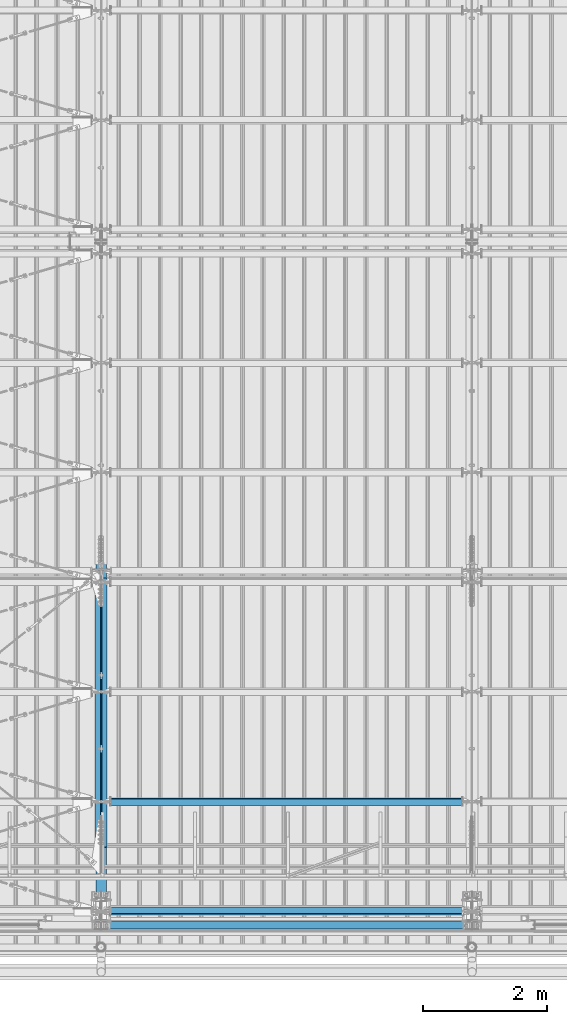
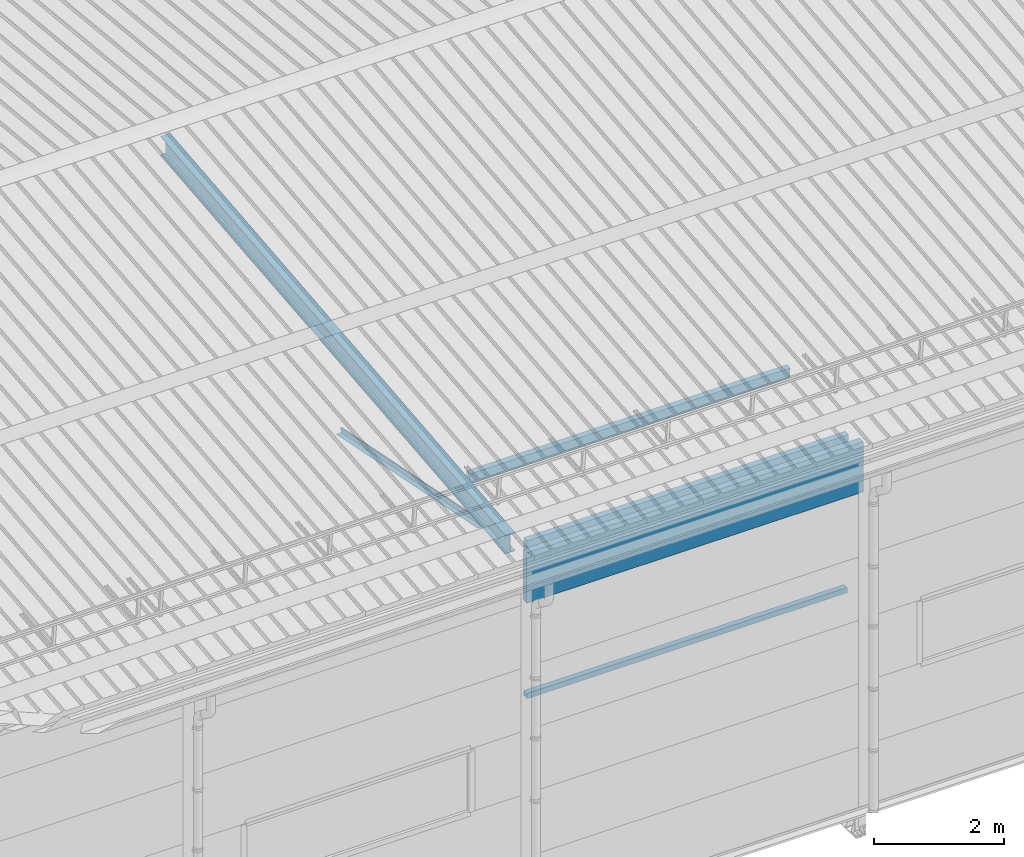
# One storey, part 243 of 709: 7 beams, 7 elements without a shape of their own.
"""IFC4 building model written with IfcOpenShell, lengths in millimetres."""

from ifc_helpers import new_model, si_unit, direction, frame, origin_with_axes, place, context, subcontext, project, spatial, polygons, material, element, aggregate, save


model = new_model("IFC4")

# Units and contexts
model_context = context("Model", 3, precision=0.2, world=origin_with_axes(), true_north=direction((0.0, 1.0)))
body_context = subcontext(model_context, "Body", "Model", "MODEL_VIEW")
ifc_project = project(units=[si_unit("LENGTHUNIT", "METRE", prefix="MILLI"), si_unit("AREAUNIT", "SQUARE_METRE"), si_unit("VOLUMEUNIT", "CUBIC_METRE"), si_unit("MASSUNIT", "GRAM", prefix="KILO"), si_unit("TIMEUNIT", "SECOND"), si_unit("PLANEANGLEUNIT", "RADIAN"), si_unit("SOLIDANGLEUNIT", "STERADIAN"), si_unit("THERMODYNAMICTEMPERATUREUNIT", "DEGREE_CELSIUS"), si_unit("LUMINOUSINTENSITYUNIT", "LUMEN")], contexts=[model_context])

# Site, building, storey
site_placement = place(None, origin_with_axes())
site = spatial("IfcSite", under=ifc_project, at=site_placement, CompositionType="ELEMENT")
building_placement = place(site_placement, origin_with_axes())
building = spatial("IfcBuilding", under=site, at=building_placement, Name="Undefined", CompositionType="ELEMENT")
storey_placement = place(building_placement, origin_with_axes())
storey = spatial("IfcBuildingStorey", under=building, at=storey_placement, Name="Undefined", CompositionType="ELEMENT", Elevation=0.0)

# Assembly, beam
assembly_1_placement = place(storey_placement, frame((10000.0, 346.0, 7089.70002), z_axis=(1.0, 0.0, 0.0), x_axis=(0.0, 0.9950371902, 0.099503719)))
assembly_1 = element("IfcElementAssembly", 1, at=assembly_1_placement, inside=storey)
ifc_material_1 = material(Name="C355-5", Category="STEEL")
beam_1_placement = place(assembly_1_placement, origin_with_axes())
beam_1 = element("IfcBeam", 2, at=beam_1_placement, material=ifc_material_1, ObjectType="432", context=body_context, shape_type="Tessellation", body=[
    polygons([(3.80474, -173.0, -87.0), (4.70474, -164.0, -87.0), (10665.6128, -164.0, -87.0), (10664.7128, -173.0, -87.0), (4.70474, -164.0, -3.0), (10665.6128, -164.0, -3.0), (37.50474, 164.0, -3.0), (10698.4128, 164.0, -3.0), (37.50474, 164.0, -87.0), (10698.4128, 164.0, -87.0), (38.40474, 173.0, -87.0), (10699.3128, 173.0, -87.0), (38.40474, 173.0, 87.0), (10699.3128, 173.0, 87.0), (37.50474, 164.0, 87.0), (10698.4128, 164.0, 87.0), (37.50474, 164.0, 3.0), (10698.4128, 164.0, 3.0), (4.70474, -164.0, 3.0), (10665.6128, -164.0, 3.0), (4.70474, -164.0, 87.0), (10665.6128, -164.0, 87.0), (3.80474, -173.0, 87.0), (10664.7128, -173.0, 87.0)], [[[1, 2, 3, 4]], [[2, 5, 6, 3]], [[5, 7, 8, 6]], [[7, 9, 10, 8]], [[9, 11, 12, 10]], [[11, 13, 14, 12]], [[13, 15, 16, 14]], [[15, 17, 18, 16]], [[17, 19, 20, 18]], [[19, 21, 22, 20]], [[21, 23, 24, 22]], [[23, 1, 4, 24]], [[6, 8, 10, 12, 14, 16, 18, 20, 22, 24, 4, 3]], [[23, 21, 19, 17, 15, 13, 11, 9, 7, 5, 2, 1]]], closed=True),
])
aggregate(assembly_1, [beam_1])

assembly_2_placement = place(storey_placement, frame((9949.0, 350.0596, 7109.99804), z_axis=(0.0, 0.1961161349, 0.9805806757), x_axis=(0.0, 0.9805806757, -0.1961161349)))
assembly_2 = element("IfcElementAssembly", 3, at=assembly_2_placement, inside=storey)
ifc_material_2 = material(Name="C345-5", Category="STEEL")
beam_2_placement = place(assembly_2_placement, origin_with_axes())
beam_2 = element("IfcBeam", 4, at=beam_2_placement, material=ifc_material_2, ObjectType="435", context=body_context, shape_type="Tessellation", body=[
    polygons([(873.96605, -45.0, -45.0), (873.96605, 45.0, -45.0), (5317.375, 45.0, -45.0), (5317.375, -45.0, -45.0), (873.96605, 45.0, -39.0), (5317.375, 45.0, -39.0), (873.96605, -39.0, -39.0), (5317.375, -39.0, -39.0), (873.96605, -39.0, 45.0), (5317.375, -39.0, 45.0), (873.96605, -45.0, 45.0), (5317.375, -45.0, 45.0)], [[[1, 2, 3, 4]], [[2, 5, 6, 3]], [[5, 7, 8, 6]], [[7, 9, 10, 8]], [[9, 11, 12, 10]], [[11, 1, 4, 12]], [[6, 8, 10, 12, 4, 3]], [[11, 9, 7, 5, 2, 1]]], closed=True),
])
aggregate(assembly_2, [beam_2])

assembly_3_placement = place(storey_placement, frame((10051.0, 5677.0596, 6044.59804), z_axis=(0.0, 0.1961161349, 0.9805806757), x_axis=(0.0, -0.9805806757, 0.1961161349)))
assembly_3 = element("IfcElementAssembly", 5, at=assembly_3_placement, inside=storey)
beam_3_placement = place(assembly_3_placement, origin_with_axes())
beam_3 = element("IfcBeam", 6, at=beam_3_placement, material=ifc_material_2, ObjectType="435", context=body_context, shape_type="Tessellation", body=[
    polygons([(115.12039, -45.0, -45.0), (115.12039, 45.0, -45.0), (4558.52934, 45.0, -45.0), (4558.52934, -45.0, -45.0), (115.12039, 45.0, -39.0), (4558.52934, 45.0, -39.0), (115.12039, -39.0, -39.0), (4558.52934, -39.0, -39.0), (115.12039, -39.0, 45.0), (4558.52934, -39.0, 45.0), (115.12039, -45.0, 45.0), (4558.52934, -45.0, 45.0)], [[[1, 2, 3, 4]], [[2, 5, 6, 3]], [[5, 7, 8, 6]], [[7, 9, 10, 8]], [[9, 11, 12, 10]], [[11, 1, 4, 12]], [[6, 8, 10, 12, 4, 3]], [[11, 9, 7, 5, 2, 1]]], closed=True),
])
aggregate(assembly_3, [beam_3])

assembly_4_placement = place(storey_placement, frame((10000.0, 173.0, 4310.0), z_axis=(0.0, 0.0, -1.0), x_axis=(1.0, 0.0, 0.0)))
assembly_4 = element("IfcElementAssembly", 7, at=assembly_4_placement, inside=storey)
ifc_material_3 = material(Name="C355", Category="STEEL")
beam_4_placement = place(assembly_4_placement, origin_with_axes())
beam_4 = element("IfcBeam", 8, at=beam_4_placement, material=ifc_material_3, ObjectType="546", context=body_context, shape_type="Tessellation", body=[
    polygons([(155.0, -47.0, -47.0), (155.0, -47.0, 47.0), (5845.0, -47.0, 47.0), (5845.0, -47.0, -47.0), (155.0, 47.0, 47.0), (5845.0, 47.0, 47.0), (155.0, 47.0, -47.0), (5845.0, 47.0, -47.0), (155.0, -50.0, -50.0), (155.0, 50.0, -50.0), (5845.0, 50.0, -50.0), (5845.0, -50.0, -50.0), (155.0, 50.0, 50.0), (5845.0, 50.0, 50.0), (155.0, -50.0, 50.0), (5845.0, -50.0, 50.0)], [[[1, 2, 3, 4]], [[2, 5, 6, 3]], [[5, 7, 8, 6]], [[7, 1, 4, 8]], [[9, 10, 11, 12]], [[10, 13, 14, 11]], [[13, 15, 16, 14]], [[15, 9, 12, 16]], [[14, 16, 12, 11], [6, 8, 4, 3]], [[15, 13, 10, 9], [7, 5, 2, 1]]], closed=True),
])
aggregate(assembly_4, [beam_4])

assembly_5_placement = place(storey_placement, frame((10000.0, 158.95533, 7154.40952), z_axis=(0.0, 0.9950371902, 0.099503719), x_axis=(1.0, 0.0, 0.0)))
assembly_5 = element("IfcElementAssembly", 9, at=assembly_5_placement, inside=storey)
beam_5_placement = place(assembly_5_placement, origin_with_axes())
beam_5 = element("IfcBeam", 10, at=beam_5_placement, material=ifc_material_3, ObjectType="578", context=body_context, shape_type="Tessellation", body=[
    polygons([(145.0, -86.0, -46.0), (145.0, -86.0, 46.0), (5855.0, -86.0, 46.0), (5855.0, -86.0, -46.0), (145.0, 86.0, 46.0), (5855.0, 86.0, 46.0), (145.0, 86.0, -46.0), (5855.0, 86.0, -46.0), (145.0, -90.0, -50.0), (145.0, 90.0, -50.0), (5855.0, 90.0, -50.0), (5855.0, -90.0, -50.0), (145.0, 90.0, 50.0), (5855.0, 90.0, 50.0), (145.0, -90.0, 50.0), (5855.0, -90.0, 50.0)], [[[1, 2, 3, 4]], [[2, 5, 6, 3]], [[5, 7, 8, 6]], [[7, 1, 4, 8]], [[9, 10, 11, 12]], [[10, 13, 14, 11]], [[13, 15, 16, 14]], [[15, 9, 12, 16]], [[14, 16, 12, 11], [6, 8, 4, 3]], [[15, 13, 10, 9], [7, 5, 2, 1]]], closed=True),
])
aggregate(assembly_5, [beam_5])

assembly_6_placement = place(storey_placement, frame((10000.0, 1936.65012, 7322.12913), z_axis=(0.0, 0.9950371902, 0.099503719), x_axis=(1.0, 0.0, 0.0)))
assembly_6 = element("IfcElementAssembly", 11, at=assembly_6_placement, inside=storey)
beam_6_placement = place(assembly_6_placement, origin_with_axes())
beam_6 = element("IfcBeam", 12, at=beam_6_placement, material=ifc_material_3, ObjectType="579", context=body_context, shape_type="Tessellation", body=[
    polygons([(155.0, -96.0, -46.0), (155.0, -96.0, 46.0), (5845.0, -96.0, 46.0), (5845.0, -96.0, -46.0), (155.0, 96.0, 46.0), (5845.0, 96.0, 46.0), (155.0, 96.0, -46.0), (5845.0, 96.0, -46.0), (155.0, -100.0, -50.0), (155.0, 100.0, -50.0), (5845.0, 100.0, -50.0), (5845.0, -100.0, -50.0), (155.0, 100.0, 50.0), (5845.0, 100.0, 50.0), (155.0, -100.0, 50.0), (5845.0, -100.0, 50.0)], [[[1, 2, 3, 4]], [[2, 5, 6, 3]], [[5, 7, 8, 6]], [[7, 1, 4, 8]], [[9, 10, 11, 12]], [[10, 13, 14, 11]], [[13, 15, 16, 14]], [[15, 9, 12, 16]], [[14, 16, 12, 11], [6, 8, 4, 3]], [[15, 13, 10, 9], [7, 5, 2, 1]]], closed=True),
])
aggregate(assembly_6, [beam_6])

assembly_7_placement = place(storey_placement, frame((10010.0, -60.0, 6845.0), z_axis=(0.0, 0.0, -1.0), x_axis=(1.0, 0.0, 0.0)))
assembly_7 = element("IfcElementAssembly", 13, at=assembly_7_placement, inside=storey)
ifc_material_4 = material(Name="Insulation", Category="Insulation")
beam_7_placement = place(assembly_7_placement, origin_with_axes())
beam_7 = element("IfcBeam", 14, at=beam_7_placement, material=ifc_material_4, ObjectType="P-108", context=body_context, shape_type="Tessellation", body=[
    polygons([(0.0, 60.0, 595.0), (0.0, -60.0, 595.0), (5980.0, -60.0, 595.0), (5980.0, 60.0, 595.0), (5980.0, 60.0, -351.923), (0.0, 60.0, -351.923), (0.0, -60.0, -351.923), (5980.0, -60.0, -351.923)], [[[1, 2, 3, 4]], [[1, 4, 5, 6]], [[2, 1, 6, 7]], [[3, 2, 7, 8]], [[4, 3, 8, 5]], [[7, 6, 5, 8]]], closed=True),
])
aggregate(assembly_7, [beam_7])

save(model, "model.ifc")
